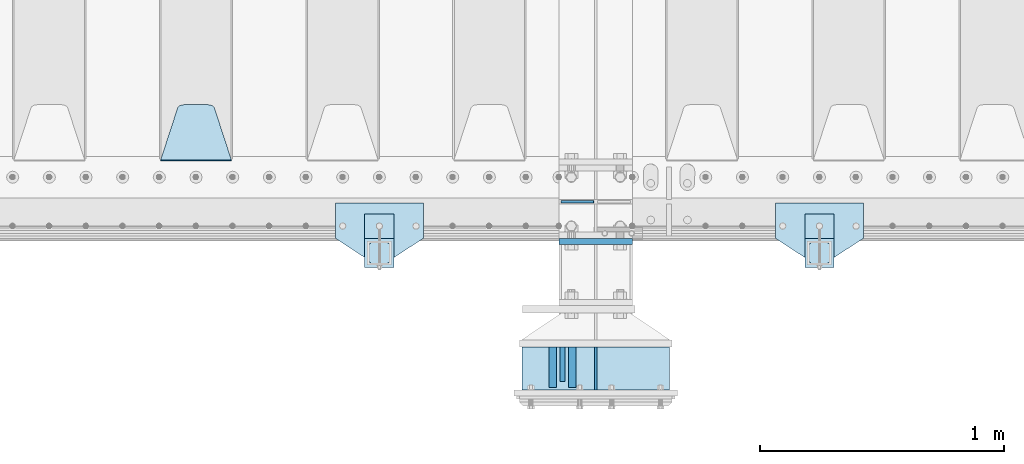
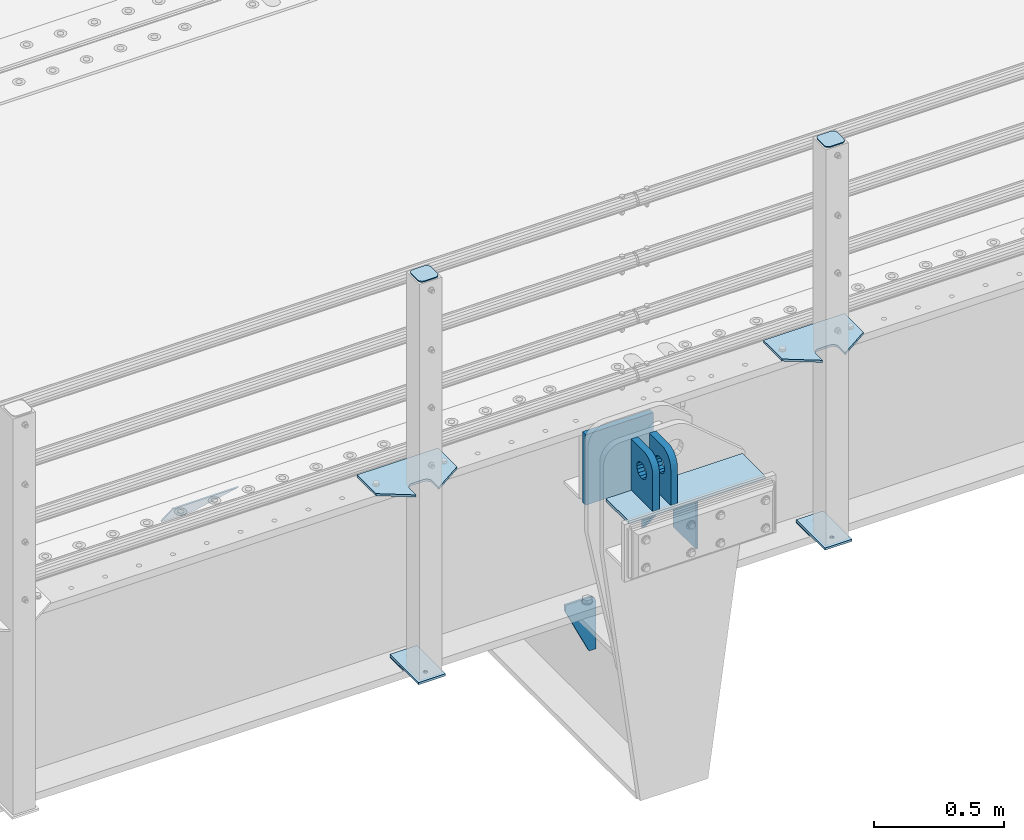
# One storey, part 207 of 242: 16 plates.
"""IFC2X3 building model written with IfcOpenShell, lengths in millimetres."""

from ifc_helpers import new_model, si_unit, frame, origin_with_axes, place, context, subcontext, project, spatial, faceted_brep, material, type_object, element, save


model = new_model("IFC2X3")

# Units and contexts
model_context = context("Model", 3, precision=1e-05, world=origin_with_axes())
body_context = subcontext(model_context, "Body", "Model", "MODEL_VIEW")
ifc_project = project(units=[si_unit("LENGTHUNIT", "METRE", prefix="MILLI"), si_unit("AREAUNIT", "SQUARE_METRE"), si_unit("VOLUMEUNIT", "CUBIC_METRE"), si_unit("MASSUNIT", "GRAM", prefix="KILO"), si_unit("TIMEUNIT", "SECOND"), si_unit("PLANEANGLEUNIT", "RADIAN"), si_unit("SOLIDANGLEUNIT", "STERADIAN"), si_unit("THERMODYNAMICTEMPERATUREUNIT", "DEGREE_CELSIUS"), si_unit("LUMINOUSINTENSITYUNIT", "LUMEN")], contexts=[model_context])

# Site, building, storey
site_placement = place(None, origin_with_axes())
site = spatial("IfcSite", under=ifc_project, at=site_placement, CompositionType="ELEMENT")
building_placement = place(site_placement, origin_with_axes())
building = spatial("IfcBuilding", under=site, at=building_placement, Name="Standard", CompositionType="ELEMENT")
storey_placement = place(building_placement, origin_with_axes())
storey = spatial("IfcBuildingStorey", under=building, at=storey_placement, Name="Undefined", CompositionType="ELEMENT", Elevation=0.0)

# Plates
ifc_material_1 = material(Name="STEEL/S355N")
plate_type_1 = type_object("IfcPlateType", PredefinedType="NOTDEFINED")
plate_1_placement = place(storey_placement, frame((-28414.9999999406, -24770.0000000349, -24.0000182225592), z_axis=(0.0, 0.0, -1.0), x_axis=(0.0, 1.0, 0.0)))
element("IfcPlate", 1, at=plate_1_placement, inside=storey, type_object=plate_type_1, material=ifc_material_1, context=body_context, shape_type="Brep", body=[
    faceted_brep([(0.0, -5.0, 0.0), (0.0, -5.0, 222.0), (0.0, 5.0, 222.0), (0.0, 5.0, 0.0), (175.0, -5.0, 222.0), (175.0, 5.0, 222.0), (175.0, -5.0, 0.0), (175.0, 5.0, 0.0)], [[[0, 1, 2, 3]], [[1, 4, 5, 2]], [[4, 6, 7, 5]], [[6, 0, 3, 7]], [[5, 7, 3, 2]], [[6, 4, 1, 0]]]),
])
plate_type_2 = type_object("IfcPlateType", PredefinedType="NOTDEFINED")
plate_2_placement = place(storey_placement, frame((-28550.5000001149, -24734.999999964, -24.0000182219301), z_axis=(0.0, 0.0, -1.0), x_axis=(0.0, 1.0, 0.0)))
element("IfcPlate", 2, at=plate_2_placement, inside=storey, type_object=plate_type_2, material=ifc_material_1, context=body_context, shape_type="Brep", body=[
    faceted_brep([(0.0, -10.0, 0.0), (140.0, -10.0, 180.0), (140.0, 10.0, 180.0), (0.0, 10.0, 0.0), (140.0, -10.0, -1.81898940354586e-12), (140.0, 10.0, -1.81898940354586e-12)], [[[0, 1, 2, 3]], [[1, 4, 5, 2]], [[4, 0, 3, 5]], [[5, 3, 2]], [[4, 1, 0]]]),
])
plate_type_3 = type_object("IfcPlateType", PredefinedType="NOTDEFINED")
plate_3_placement = place(storey_placement, frame((-28510.5000001165, -24594.9999999639, -10.0000182219628), z_axis=(0.0, -1.0, 0.0), x_axis=(0.0, 0.0, 1.0)))
element("IfcPlate", 3, at=plate_3_placement, inside=storey, type_object=plate_type_3, material=ifc_material_1, context=body_context, shape_type="Brep", body=[
    faceted_brep([(125.840713002497, -14.9999995435392, 45.8164574470829), (125.840713002497, 15.0000004564608, 45.8164571470843), (113.837049096103, 15.0000005366674, 53.8370489461013), (113.837049096103, -14.9999994633326, 53.8370492460999), (105.816457297088, 15.0000006567025, 65.8407128524959), (105.816457297088, -14.9999993432975, 65.8407131524946), (103.000000000005, 15.0000007982962, 79.9999998500025), (103.000000000005, -14.9999992017038, 80.0000001500011), (105.816457297088, 15.00000093989, 94.1592868475091), (105.816457297088, -14.99999906011, 94.1592871475077), (113.837049096103, 15.0000010599251, 106.162950753904), (113.837049096103, -14.9999989400749, 106.162951053902), (125.840713002497, 15.0000011401316, 114.183542552921), (125.840713002497, -14.9999988598684, 114.183542852919), (140.000000000005, 15.0000011682969, 116.999999850003), (140.000000000005, -14.9999988317031, 117.000000150001), (154.159286997514, 15.0000011401316, 114.183542552921), (154.159286997514, -14.9999988598684, 114.183542852919), (166.162950903908, 15.0000010599251, 106.162950753904), (166.162950903908, -14.9999989400749, 106.162951053902), (174.183542702923, 15.00000093989, 94.1592868475091), (174.183542702923, -14.99999906011, 94.1592871475077), (177.000000000005, 15.0000007982962, 79.9999998500025), (177.000000000005, -14.9999992017038, 80.0000001500011), (174.183542702923, 15.0000006567025, 65.8407128524959), (174.183542702923, -14.9999993432975, 65.8407131524946), (166.162950903908, 15.0000005366674, 53.8370489461013), (166.162950903908, -14.9999994633326, 53.8370492460999), (154.159286997514, 15.0000004564608, 45.8164571470843), (154.159286997514, -14.9999995435392, 45.8164574470829), (140.000000000005, 15.0000004282956, 42.9999998500025), (140.000000000005, -14.9999995717044, 43.0000001500011), (240.000015258789, -14.9999999999964, -2.03726813197136e-10), (240.001666876698, -15.0, 94.9959403776229), (237.616787699976, -15.0, 113.113322498935), (230.624045898169, -15.0, 129.996116868067), (219.499985670386, -14.9999999999964, 144.493787979864), (205.002693976271, -14.9999999999964, 155.618342674454), (188.120138118986, -15.0, 162.611660295068), (170.002837349484, -15.0, 164.997157401463), (-1.40620068123098e-06, -15.0, 165.0), (0.0, -15.0, 0.0), (0.0, 15.0, 0.0), (240.000015258789, 15.0000000000036, -2.03726813197136e-10), (240.001666876698, 15.0, 94.9959403776265), (237.616787699976, 15.0, 113.113322498935), (230.624045898169, 15.0, 129.996116868067), (219.499985670386, 15.0000000000036, 144.493787979864), (205.002693976271, 15.0000000000036, 155.618342674454), (188.120138118986, 15.0, 162.611660295068), (170.002837349484, 15.0, 164.997157401463), (-1.40620068123098e-06, 15.0, 165.000000000004)], [[[0, 1, 2, 3]], [[3, 2, 4, 5]], [[5, 4, 6, 7]], [[7, 6, 8, 9]], [[9, 8, 10, 11]], [[11, 10, 12, 13]], [[13, 12, 14, 15]], [[15, 14, 16, 17]], [[17, 16, 18, 19]], [[19, 18, 20, 21]], [[21, 20, 22, 23]], [[23, 22, 24, 25]], [[25, 24, 26, 27]], [[27, 26, 28, 29]], [[29, 28, 30, 31]], [[31, 30, 1, 0]], [[32, 33, 34, 35, 36, 37, 38, 39, 40, 41], [3, 5, 7, 9, 11, 13, 15, 17, 19, 21, 23, 25, 27, 29, 31, 0]], [[32, 41, 42, 43]], [[33, 32, 43, 44]], [[34, 33, 44, 45]], [[35, 34, 45, 46]], [[36, 35, 46, 47]], [[37, 36, 47, 48]], [[38, 37, 48, 49]], [[39, 38, 49, 50]], [[40, 39, 50, 51]], [[41, 40, 51, 42]], [[50, 49, 48, 47, 46, 45, 44, 43, 42, 51], [26, 24, 22, 20, 18, 16, 14, 12, 10, 8, 6, 4, 2, 1, 30, 28]]]),
])
plate_4_placement = place(storey_placement, frame((-28590.5000001148, -24594.9999999639, -10.0000182219628), z_axis=(0.0, -1.0, 0.0), x_axis=(0.0, 0.0, 1.0)))
element("IfcPlate", 4, at=plate_4_placement, inside=storey, type_object=plate_type_3, material=ifc_material_1, context=body_context, shape_type="Brep", body=[
    faceted_brep([(125.840713002497, -14.9999995435392, 45.8164574470829), (125.840713002497, 15.0000004564608, 45.8164571470843), (113.837049096103, 15.0000005366674, 53.8370489461013), (113.837049096103, -14.9999994633326, 53.8370492460999), (105.816457297088, 15.0000006567025, 65.8407128524959), (105.816457297088, -14.9999993432975, 65.8407131524946), (103.000000000005, 15.0000007982962, 79.9999998500025), (103.000000000005, -14.9999992017038, 80.0000001500011), (105.816457297088, 15.00000093989, 94.1592868475091), (105.816457297088, -14.99999906011, 94.1592871475077), (113.837049096103, 15.0000010599251, 106.162950753904), (113.837049096103, -14.9999989400749, 106.162951053902), (125.840713002497, 15.0000011401316, 114.183542552921), (125.840713002497, -14.9999988598684, 114.183542852919), (140.000000000005, 15.0000011682969, 116.999999850003), (140.000000000005, -14.9999988317031, 117.000000150001), (154.159286997514, 15.0000011401316, 114.183542552921), (154.159286997514, -14.9999988598684, 114.183542852919), (166.162950903908, 15.0000010599251, 106.162950753904), (166.162950903908, -14.9999989400749, 106.162951053902), (174.183542702923, 15.00000093989, 94.1592868475091), (174.183542702923, -14.99999906011, 94.1592871475077), (177.000000000005, 15.0000007982962, 79.9999998500025), (177.000000000005, -14.9999992017038, 80.0000001500011), (174.183542702923, 15.0000006567025, 65.8407128524959), (174.183542702923, -14.9999993432975, 65.8407131524946), (166.162950903908, 15.0000005366674, 53.8370489461013), (166.162950903908, -14.9999994633326, 53.8370492460999), (154.159286997514, 15.0000004564608, 45.8164571470843), (154.159286997514, -14.9999995435392, 45.8164574470829), (140.000000000005, 15.0000004282956, 42.9999998500025), (140.000000000005, -14.9999995717044, 43.0000001500011), (240.000015258789, -14.9999999999964, -2.03726813197136e-10), (240.0, -15.0, 95.0), (237.614807840235, -15.0, 113.117333157177), (230.621778264911, -15.0, 130.0), (219.497474683058, -15.0, 144.497474683059), (205.0, -15.0, 155.621778264911), (188.117333157176, -15.0, 162.614807840237), (170.0, -15.0, 165.0), (-1.40620068123098e-06, -15.0, 165.0), (0.0, -15.0, 0.0), (0.0, 15.0, 0.0), (240.000015258789, 15.0000000000036, -2.03726813197136e-10), (240.0, 15.0, 95.0), (237.614807840235, 15.0, 113.117333157177), (230.621778264911, 15.0, 130.0), (219.497474683058, 15.0, 144.497474683059), (205.0, 15.0, 155.621778264911), (188.117333157176, 15.0, 162.614807840237), (170.0, 15.0, 165.0), (-1.40620068123098e-06, 15.0, 165.000000000004)], [[[0, 1, 2, 3]], [[3, 2, 4, 5]], [[5, 4, 6, 7]], [[7, 6, 8, 9]], [[9, 8, 10, 11]], [[11, 10, 12, 13]], [[13, 12, 14, 15]], [[15, 14, 16, 17]], [[17, 16, 18, 19]], [[19, 18, 20, 21]], [[21, 20, 22, 23]], [[23, 22, 24, 25]], [[25, 24, 26, 27]], [[27, 26, 28, 29]], [[29, 28, 30, 31]], [[31, 30, 1, 0]], [[32, 33, 34, 35, 36, 37, 38, 39, 40, 41], [3, 5, 7, 9, 11, 13, 15, 17, 19, 21, 23, 25, 27, 29, 31, 0]], [[32, 41, 42, 43]], [[33, 32, 43, 44]], [[34, 33, 44, 45]], [[35, 34, 45, 46]], [[36, 35, 46, 47]], [[37, 36, 47, 48]], [[38, 37, 48, 49]], [[39, 38, 49, 50]], [[40, 39, 50, 51]], [[41, 40, 51, 42]], [[50, 49, 48, 47, 46, 45, 44, 43, 42, 51], [26, 24, 22, 20, 18, 16, 14, 12, 10, 8, 6, 4, 2, 1, 30, 28]]]),
])
ifc_material_2 = material(Name="STEEL/S355J2")
plate_type_4 = type_object("IfcPlateType", PredefinedType="NOTDEFINED")
plate_5_placement = place(storey_placement, frame((-29120.0, -24005.0, 5.00000000004911), z_axis=(0.0, -1.0, 0.0), x_axis=(-1.0, 0.0, 0.0)))
element("IfcPlate", 5, at=plate_5_placement, inside=storey, type_object=plate_type_4, material=ifc_material_2, context=body_context, shape_type="Brep", body=[
    faceted_brep([(0.0, -5.0, 0.0), (2.31396552408114e-06, -5.0, 145.0), (2.31396552408114e-06, 5.0, 145.0), (0.0, 5.0, 0.0), (130.0, -5.0, 230.0), (130.0, 5.0, 230.0), (130.0, -5.0, 180.0), (130.0, 5.0, 180.0), (130.48036798992, -5.0, 175.122741949595), (130.48036798992, 5.0, 175.122741949595), (131.903011687216, -5.0, 170.432914190871), (131.903011687216, 5.0, 170.432914190871), (134.213259692435, -5.0, 166.110744174512), (134.213259692435, 5.0, 166.110744174512), (137.322330470335, -5.0, 162.322330470335), (137.322330470335, 5.0, 162.322330470335), (141.110744174512, -5.0, 159.213259692435), (141.110744174512, 5.0, 159.213259692435), (145.432914190871, -5.0, 156.903011687216), (145.432914190871, 5.0, 156.903011687216), (150.122741949595, -5.0, 155.48036798992), (150.122741949595, 5.0, 155.48036798992), (155.0, -5.0, 155.0), (155.0, 5.0, 155.0), (205.0, -5.0, 155.0), (205.0, 5.0, 155.0), (209.877258050405, -5.0, 155.48036798992), (209.877258050405, 5.0, 155.48036798992), (214.567085809129, -5.0, 156.903011687216), (214.567085809129, 5.0, 156.903011687216), (218.889255825488, -5.0, 159.213259692435), (218.889255825488, 5.0, 159.213259692435), (222.677669529665, -5.0, 162.322330470335), (222.677669529665, 5.0, 162.322330470335), (225.786740307565, -5.0, 166.110744174512), (225.786740307565, 5.0, 166.110744174512), (228.096988312784, -5.0, 170.432914190871), (228.096988312784, 5.0, 170.432914190871), (229.51963201008, -5.0, 175.122741949595), (229.51963201008, 5.0, 175.122741949595), (230.0, -5.0, 180.0), (230.0, 5.0, 180.0), (230.0, -5.0, 230.0), (230.0, 5.0, 230.0), (360.0, -5.0, 145.0), (360.0, 5.0, 145.0), (360.0, -5.0, -7.27595761418343e-12), (360.0, 5.0, -7.27595761418343e-12)], [[[0, 1, 2, 3]], [[1, 4, 5, 2]], [[4, 6, 7, 5]], [[6, 8, 9, 7]], [[8, 10, 11, 9]], [[10, 12, 13, 11]], [[12, 14, 15, 13]], [[14, 16, 17, 15]], [[16, 18, 19, 17]], [[18, 20, 21, 19]], [[20, 22, 23, 21]], [[22, 24, 25, 23]], [[24, 26, 27, 25]], [[26, 28, 29, 27]], [[28, 30, 31, 29]], [[30, 32, 33, 31]], [[32, 34, 35, 33]], [[34, 36, 37, 35]], [[36, 38, 39, 37]], [[38, 40, 41, 39]], [[40, 42, 43, 41]], [[42, 44, 45, 43]], [[44, 46, 47, 45]], [[46, 0, 3, 47]], [[5, 7, 9, 11, 13, 15, 17, 19, 21, 23, 25, 27, 29, 31, 33, 35, 37, 39, 41, 43, 45, 47, 3, 2]], [[46, 44, 42, 40, 38, 36, 34, 32, 30, 28, 26, 24, 22, 20, 18, 16, 14, 12, 10, 8, 6, 4, 1, 0]]]),
])
plate_6_placement = place(storey_placement, frame((-27320.0, -24005.0, 5.00000000004911), z_axis=(0.0, -1.0, 0.0), x_axis=(-1.0, 0.0, 0.0)))
element("IfcPlate", 6, at=plate_6_placement, inside=storey, type_object=plate_type_4, material=ifc_material_2, context=body_context, shape_type="Brep", body=[
    faceted_brep([(0.0, -5.0, 0.0), (2.31396552408114e-06, -5.0, 145.0), (2.31396552408114e-06, 5.0, 145.0), (0.0, 5.0, 0.0), (130.0, -5.0, 230.0), (130.0, 5.0, 230.0), (130.0, -5.0, 180.0), (130.0, 5.0, 180.0), (130.48036798992, -5.0, 175.122741949595), (130.48036798992, 5.0, 175.122741949595), (131.903011687216, -5.0, 170.432914190871), (131.903011687216, 5.0, 170.432914190871), (134.213259692435, -5.0, 166.110744174512), (134.213259692435, 5.0, 166.110744174512), (137.322330470335, -5.0, 162.322330470335), (137.322330470335, 5.0, 162.322330470335), (141.110744174512, -5.0, 159.213259692435), (141.110744174512, 5.0, 159.213259692435), (145.432914190871, -5.0, 156.903011687216), (145.432914190871, 5.0, 156.903011687216), (150.122741949595, -5.0, 155.48036798992), (150.122741949595, 5.0, 155.48036798992), (155.0, -5.0, 155.0), (155.0, 5.0, 155.0), (205.0, -5.0, 155.0), (205.0, 5.0, 155.0), (209.877258050405, -5.0, 155.48036798992), (209.877258050405, 5.0, 155.48036798992), (214.567085809129, -5.0, 156.903011687216), (214.567085809129, 5.0, 156.903011687216), (218.889255825488, -5.0, 159.213259692435), (218.889255825488, 5.0, 159.213259692435), (222.677669529665, -5.0, 162.322330470335), (222.677669529665, 5.0, 162.322330470335), (225.786740307565, -5.0, 166.110744174512), (225.786740307565, 5.0, 166.110744174512), (228.096988312784, -5.0, 170.432914190871), (228.096988312784, 5.0, 170.432914190871), (229.51963201008, -5.0, 175.122741949595), (229.51963201008, 5.0, 175.122741949595), (230.0, -5.0, 180.0), (230.0, 5.0, 180.0), (230.0, -5.0, 230.0), (230.0, 5.0, 230.0), (360.0, -5.0, 145.0), (360.0, 5.0, 145.0), (360.0, -5.0, -7.27595761418343e-12), (360.0, 5.0, -7.27595761418343e-12)], [[[0, 1, 2, 3]], [[1, 4, 5, 2]], [[4, 6, 7, 5]], [[6, 8, 9, 7]], [[8, 10, 11, 9]], [[10, 12, 13, 11]], [[12, 14, 15, 13]], [[14, 16, 17, 15]], [[16, 18, 19, 17]], [[18, 20, 21, 19]], [[20, 22, 23, 21]], [[22, 24, 25, 23]], [[24, 26, 27, 25]], [[26, 28, 29, 27]], [[28, 30, 31, 29]], [[30, 32, 33, 31]], [[32, 34, 35, 33]], [[34, 36, 37, 35]], [[36, 38, 39, 37]], [[38, 40, 41, 39]], [[40, 42, 43, 41]], [[42, 44, 45, 43]], [[44, 46, 47, 45]], [[46, 0, 3, 47]], [[5, 7, 9, 11, 13, 15, 17, 19, 21, 23, 25, 27, 29, 31, 33, 35, 37, 39, 41, 43, 45, 47, 3, 2]], [[46, 44, 42, 40, 38, 36, 34, 32, 30, 28, 26, 24, 22, 20, 18, 16, 14, 12, 10, 8, 6, 4, 1, 0]]]),
])
plate_type_5 = type_object("IfcPlateType", PredefinedType="NOTDEFINED")
for number, where, z_axis, x_axis in (
    (7, (-29240.0000000001, -24050.0000000002, -850.000000000002), (0.0, -1.0, 0.0), (-1.0, 0.0, 0.0)),
    (8, (-27440.0000000001, -24050.0000000002, -850.000000000002), (0.0, -1.0, 0.0), (-1.0, 0.0, 0.0)),
):
    element("IfcPlate", number, at=place(storey_placement, frame(where, z_axis=z_axis, x_axis=x_axis)), inside=storey, type_object=plate_type_5, material=ifc_material_2, context=body_context, shape_type="Brep", body=[
        faceted_brep([(53.6360389691836, -5.0, 176.363961030471), (53.6360389691836, 5.0, 176.363961030471), (59.9999999998618, 5.0, 178.999999999793), (59.9999999998618, -5.0, 178.999999999793), (66.3639610305399, 5.0, 176.363961030471), (66.3639610305399, -5.0, 176.363961030471), (68.9999999998618, 5.0, 169.999999999793), (68.9999999998618, -5.0, 169.999999999793), (66.3639610305399, 5.0, 163.636038969114), (66.3639610305399, -5.0, 163.636038969114), (59.9999999998618, 5.0, 160.999999999793), (59.9999999998618, -5.0, 160.999999999793), (53.6360389691836, 5.0, 163.636038969114), (53.6360389691836, -5.0, 163.636038969114), (50.9999999998618, 5.0, 169.999999999793), (50.9999999998618, -5.0, 169.999999999793), (120.0, -5.0, 0.0), (120.0, -5.0, 220.0), (0.0, -5.0, 220.0), (0.0, -5.0, 0.0), (0.0, 5.0, 0.0), (120.0, 5.0, 0.0), (120.0, 5.0, 220.0), (0.0, 5.0, 220.0)], [[[0, 1, 2, 3]], [[3, 2, 4, 5]], [[5, 4, 6, 7]], [[7, 6, 8, 9]], [[9, 8, 10, 11]], [[11, 10, 12, 13]], [[13, 12, 14, 15]], [[15, 14, 1, 0]], [[16, 17, 18, 19], [3, 5, 7, 9, 11, 13, 15, 0]], [[16, 19, 20, 21]], [[17, 16, 21, 22]], [[18, 17, 22, 23]], [[19, 18, 23, 20]], [[22, 21, 20, 23], [10, 8, 6, 4, 2, 1, 14, 12]]]),
    ])
plate_type_6 = type_object("IfcPlateType", PredefinedType="NOTDEFINED")
plate_7_placement = place(storey_placement, frame((-29344.0000000001, -24166.0000000002, 1012.50000000001), z_axis=(0.0, -1.0, 0.0), x_axis=(1.0, 0.0, 0.0)))
element("IfcPlate", 9, at=plate_7_placement, inside=storey, type_object=plate_type_6, material=ifc_material_2, context=body_context, shape_type="Brep", body=[
    faceted_brep([(0.0, -2.5, 19.0), (0.0, -2.5, 69.0), (0.0, 2.5, 69.0), (0.0, 2.5, 19.0), (0.476369668544066, -2.5, 73.2278977451715), (0.476369668544066, 2.5, 73.2278977451715), (1.88159150985302, -2.5, 77.2437910432345), (1.88159150985302, 2.5, 77.2437910432345), (4.14520183310742, -2.5, 80.8463062353148), (4.14520183310742, 2.5, 80.8463062353148), (7.15369376468516, -2.5, 83.8547981668926), (7.15369376468516, 2.5, 83.8547981668926), (10.7562089567655, -2.5, 86.118408490147), (10.7562089567655, 2.5, 86.118408490147), (14.7721022548285, -2.5, 87.5236303314559), (14.7721022548285, 2.5, 87.5236303314559), (19.0, -2.5, 88.0), (19.0, 2.5, 88.0), (69.0, -2.5, 88.0), (69.0, 2.5, 88.0), (73.2278977451715, -2.5, 87.5236303314559), (73.2278977451715, 2.5, 87.5236303314559), (77.2437910432345, -2.5, 86.118408490147), (77.2437910432345, 2.5, 86.118408490147), (80.8463062353148, -2.5, 83.8547981668926), (80.8463062353148, 2.5, 83.8547981668926), (83.8547981668926, -2.5, 80.8463062353148), (83.8547981668926, 2.5, 80.8463062353148), (86.118408490147, -2.5, 77.2437910432345), (86.118408490147, 2.5, 77.2437910432345), (87.5236303314559, -2.5, 73.2278977451715), (87.5236303314559, 2.5, 73.2278977451715), (88.0, -2.5, 69.0), (88.0, 2.5, 69.0), (88.0, -2.5, 19.0), (88.0, 2.5, 19.0), (87.5236303314559, -2.5, 14.7721022548285), (87.5236303314559, 2.5, 14.7721022548285), (86.118408490147, -2.5, 10.7562089567655), (86.118408490147, 2.5, 10.7562089567655), (83.8547981668926, -2.5, 7.15369376468516), (83.8547981668926, 2.5, 7.15369376468516), (80.8463062353148, -2.5, 4.14520183310742), (80.8463062353148, 2.5, 4.14520183310742), (77.2437910432345, -2.5, 1.88159150985302), (77.2437910432345, 2.5, 1.88159150985302), (73.2278977451715, -2.5, 0.476369668544066), (73.2278977451715, 2.5, 0.476369668544066), (69.0, -2.5, 0.0), (69.0, 2.5, 0.0), (19.0, -2.5, 0.0), (19.0, 2.5, 0.0), (14.7721022548285, -2.5, 0.476369668544066), (14.7721022548285, 2.5, 0.476369668544066), (10.7562089567655, -2.5, 1.88159150985302), (10.7562089567655, 2.5, 1.88159150985302), (7.15369376468516, -2.5, 4.14520183310742), (7.15369376468516, 2.5, 4.14520183310742), (4.14520183310742, -2.5, 7.15369376468516), (4.14520183310742, 2.5, 7.15369376468516), (1.88159150985302, -2.5, 10.7562089567655), (1.88159150985302, 2.5, 10.7562089567655), (0.476369668544066, -2.5, 14.7721022548285), (0.476369668544066, 2.5, 14.7721022548285)], [[[0, 1, 2, 3]], [[1, 4, 5, 2]], [[4, 6, 7, 5]], [[6, 8, 9, 7]], [[8, 10, 11, 9]], [[10, 12, 13, 11]], [[12, 14, 15, 13]], [[14, 16, 17, 15]], [[16, 18, 19, 17]], [[18, 20, 21, 19]], [[20, 22, 23, 21]], [[22, 24, 25, 23]], [[24, 26, 27, 25]], [[26, 28, 29, 27]], [[28, 30, 31, 29]], [[30, 32, 33, 31]], [[32, 34, 35, 33]], [[34, 36, 37, 35]], [[36, 38, 39, 37]], [[38, 40, 41, 39]], [[40, 42, 43, 41]], [[42, 44, 45, 43]], [[44, 46, 47, 45]], [[46, 48, 49, 47]], [[48, 50, 51, 49]], [[50, 52, 53, 51]], [[52, 54, 55, 53]], [[54, 56, 57, 55]], [[56, 58, 59, 57]], [[58, 60, 61, 59]], [[60, 62, 63, 61]], [[62, 0, 3, 63]], [[5, 7, 9, 11, 13, 15, 17, 19, 21, 23, 25, 27, 29, 31, 33, 35, 37, 39, 41, 43, 45, 47, 49, 51, 53, 55, 57, 59, 61, 63, 3, 2]], [[62, 60, 58, 56, 54, 52, 50, 48, 46, 44, 42, 40, 38, 36, 34, 32, 30, 28, 26, 24, 22, 20, 18, 16, 14, 12, 10, 8, 6, 4, 1, 0]]]),
])
plate_8_placement = place(storey_placement, frame((-27544.0000000001, -24166.0000000002, 1012.50000000001), z_axis=(0.0, -1.0, 0.0), x_axis=(1.0, 0.0, 0.0)))
element("IfcPlate", 10, at=plate_8_placement, inside=storey, type_object=plate_type_6, material=ifc_material_2, context=body_context, shape_type="Brep", body=[
    faceted_brep([(0.0, -2.5, 19.0), (0.0, -2.5, 69.0), (0.0, 2.5, 69.0), (0.0, 2.5, 19.0), (0.476369668544066, -2.5, 73.2278977451715), (0.476369668544066, 2.5, 73.2278977451715), (1.88159150985302, -2.5, 77.2437910432345), (1.88159150985302, 2.5, 77.2437910432345), (4.14520183310742, -2.5, 80.8463062353148), (4.14520183310742, 2.5, 80.8463062353148), (7.15369376468516, -2.5, 83.8547981668926), (7.15369376468516, 2.5, 83.8547981668926), (10.7562089567655, -2.5, 86.118408490147), (10.7562089567655, 2.5, 86.118408490147), (14.7721022548285, -2.5, 87.5236303314559), (14.7721022548285, 2.5, 87.5236303314559), (19.0, -2.5, 88.0), (19.0, 2.5, 88.0), (69.0, -2.5, 88.0), (69.0, 2.5, 88.0), (73.2278977451715, -2.5, 87.5236303314559), (73.2278977451715, 2.5, 87.5236303314559), (77.2437910432345, -2.5, 86.118408490147), (77.2437910432345, 2.5, 86.118408490147), (80.8463062353148, -2.5, 83.8547981668926), (80.8463062353148, 2.5, 83.8547981668926), (83.8547981668926, -2.5, 80.8463062353148), (83.8547981668926, 2.5, 80.8463062353148), (86.118408490147, -2.5, 77.2437910432345), (86.118408490147, 2.5, 77.2437910432345), (87.5236303314559, -2.5, 73.2278977451715), (87.5236303314559, 2.5, 73.2278977451715), (88.0, -2.5, 69.0), (88.0, 2.5, 69.0), (88.0, -2.5, 19.0), (88.0, 2.5, 19.0), (87.5236303314559, -2.5, 14.7721022548285), (87.5236303314559, 2.5, 14.7721022548285), (86.118408490147, -2.5, 10.7562089567655), (86.118408490147, 2.5, 10.7562089567655), (83.8547981668926, -2.5, 7.15369376468516), (83.8547981668926, 2.5, 7.15369376468516), (80.8463062353148, -2.5, 4.14520183310742), (80.8463062353148, 2.5, 4.14520183310742), (77.2437910432345, -2.5, 1.88159150985302), (77.2437910432345, 2.5, 1.88159150985302), (73.2278977451715, -2.5, 0.476369668544066), (73.2278977451715, 2.5, 0.476369668544066), (69.0, -2.5, 0.0), (69.0, 2.5, 0.0), (19.0, -2.5, 0.0), (19.0, 2.5, 0.0), (14.7721022548285, -2.5, 0.476369668544066), (14.7721022548285, 2.5, 0.476369668544066), (10.7562089567655, -2.5, 1.88159150985302), (10.7562089567655, 2.5, 1.88159150985302), (7.15369376468516, -2.5, 4.14520183310742), (7.15369376468516, 2.5, 4.14520183310742), (4.14520183310742, -2.5, 7.15369376468516), (4.14520183310742, 2.5, 7.15369376468516), (1.88159150985302, -2.5, 10.7562089567655), (1.88159150985302, 2.5, 10.7562089567655), (0.476369668544066, -2.5, 14.7721022548285), (0.476369668544066, 2.5, 14.7721022548285)], [[[0, 1, 2, 3]], [[1, 4, 5, 2]], [[4, 6, 7, 5]], [[6, 8, 9, 7]], [[8, 10, 11, 9]], [[10, 12, 13, 11]], [[12, 14, 15, 13]], [[14, 16, 17, 15]], [[16, 18, 19, 17]], [[18, 20, 21, 19]], [[20, 22, 23, 21]], [[22, 24, 25, 23]], [[24, 26, 27, 25]], [[26, 28, 29, 27]], [[28, 30, 31, 29]], [[30, 32, 33, 31]], [[32, 34, 35, 33]], [[34, 36, 37, 35]], [[36, 38, 39, 37]], [[38, 40, 41, 39]], [[40, 42, 43, 41]], [[42, 44, 45, 43]], [[44, 46, 47, 45]], [[46, 48, 49, 47]], [[48, 50, 51, 49]], [[50, 52, 53, 51]], [[52, 54, 55, 53]], [[54, 56, 57, 55]], [[56, 58, 59, 57]], [[58, 60, 61, 59]], [[60, 62, 63, 61]], [[62, 0, 3, 63]], [[5, 7, 9, 11, 13, 15, 17, 19, 21, 23, 25, 27, 29, 31, 33, 35, 37, 39, 41, 43, 45, 47, 49, 51, 53, 55, 57, 59, 61, 63, 3, 2]], [[62, 60, 58, 56, 54, 52, 50, 48, 46, 44, 42, 40, 38, 36, 34, 32, 30, 28, 26, 24, 22, 20, 18, 16, 14, 12, 10, 8, 6, 4, 1, 0]]]),
])
plate_type_7 = type_object("IfcPlateType", PredefinedType="NOTDEFINED")
for number, where, z_axis, x_axis in (
    (11, (-29240.0000000001, -24050.0000000002, -857.500000000002), (0.0, -1.0, 0.0), (-1.0, 0.0, 0.0)),
    (12, (-27440.0000000001, -24050.0000000002, -857.500000000002), (0.0, -1.0, 0.0), (-1.0, 0.0, 0.0)),
):
    element("IfcPlate", number, at=place(storey_placement, frame(where, z_axis=z_axis, x_axis=x_axis)), inside=storey, type_object=plate_type_7, material=ifc_material_2, context=body_context, shape_type="Brep", body=[
        faceted_brep([(0.0, -2.5, 0.0), (0.0, -2.5, 100.0), (0.0, 2.5, 100.0), (0.0, 2.5, 0.0), (120.0, -2.5, 100.0), (120.0, 2.5, 100.0), (120.0, -2.5, 0.0), (120.0, 2.5, 0.0)], [[[0, 1, 2, 3]], [[1, 4, 5, 2]], [[4, 6, 7, 5]], [[6, 0, 3, 7]], [[5, 7, 3, 2]], [[6, 4, 1, 0]]]),
    ])
plate_type_8 = type_object("IfcPlateType", PredefinedType="NOTDEFINED")
plate_9_placement = place(storey_placement, frame((-28421.4999999409, -24000.0000000349, -925.000018222557), z_axis=(0.0, 0.0, -1.0), x_axis=(-1.0, 0.0, 0.0)))
element("IfcPlate", 13, at=plate_9_placement, inside=storey, type_object=plate_type_8, material=ifc_material_1, context=body_context, shape_type="Brep", body=[
    faceted_brep([(0.0, -5.0, 27.0), (0.0, -5.0, 250.0), (0.0, 5.0, 250.0), (0.0, 5.0, 27.0), (30.0, -5.0, 250.0), (30.0, 5.0, 250.0), (135.0, -5.0, 30.0), (135.0, 5.0, 30.0), (135.0, -5.0, 0.0), (135.0, 5.0, 0.0), (27.0, -5.0, 0.0), (27.0, 5.0, 0.0), (22.3114992029914, -5.0, 0.410190668670339), (22.3114992029914, 5.0, 0.410190668670339), (17.7654561302079, -5.0, 1.62829923878041), (17.7654561302079, 5.0, 1.62829923878041), (13.5, -5.0, 3.61731409782021), (13.5, 5.0, 3.61731409782021), (9.64473453846222, -5.0, 6.31680003578765), (9.64473453846222, 5.0, 6.31680003578765), (6.31680003578731, -5.0, 9.64473453846347), (6.31680003578731, 5.0, 9.64473453846347), (3.61731409782078, -5.0, 13.5), (3.61731409782078, 5.0, 13.5), (1.62829923877871, -5.0, 17.765456130207), (1.62829923877871, 5.0, 17.765456130207), (0.410190668670111, -5.0, 22.3114992029929), (0.410190668670111, 5.0, 22.3114992029929)], [[[0, 1, 2, 3]], [[1, 4, 5, 2]], [[4, 6, 7, 5]], [[6, 8, 9, 7]], [[8, 10, 11, 9]], [[10, 12, 13, 11]], [[12, 14, 15, 13]], [[14, 16, 17, 15]], [[16, 18, 19, 17]], [[18, 20, 21, 19]], [[20, 22, 23, 21]], [[22, 24, 25, 23]], [[24, 26, 27, 25]], [[26, 0, 3, 27]], [[5, 7, 9, 11, 13, 15, 17, 19, 21, 23, 25, 27, 3, 2]], [[26, 24, 22, 20, 18, 16, 14, 12, 10, 8, 6, 4, 1, 0]]]),
])
ifc_material_3 = material()
plate_type_9 = type_object("IfcPlateType", PredefinedType="NOTDEFINED")
plate_10_placement = place(storey_placement, frame((-28112.4999999399, -24595.000000035, -17.0000182225592), z_axis=(0.0, -1.0, 0.0), x_axis=(-1.0, 0.0, 0.0)))
element("IfcPlate", 14, at=plate_10_placement, inside=storey, type_object=plate_type_9, material=ifc_material_3, context=body_context, shape_type="Brep", body=[
    faceted_brep([(0.0, -7.0, 0.0), (0.0, -7.0, 175.0), (0.0, 7.0, 175.0), (0.0, 7.0, 0.0), (605.0, -7.0, 175.0), (605.0, 7.0, 175.0), (605.0, -7.0, 0.0), (605.0, 7.0, 0.0)], [[[0, 1, 2, 3]], [[1, 4, 5, 2]], [[4, 6, 7, 5]], [[6, 0, 3, 7]], [[5, 7, 3, 2]], [[6, 4, 1, 0]]]),
])
plate_type_10 = type_object("IfcPlateType", PredefinedType="NOTDEFINED")
plate_11_placement = place(storey_placement, frame((-28564.9999999412, -24162.5000000349, -350.000018222559), z_axis=(0.0, 0.0, 1.0), x_axis=(1.0, 0.0, 0.0)))
element("IfcPlate", 15, at=plate_11_placement, inside=storey, type_object=plate_type_10, material=ifc_material_1, context=body_context, shape_type="Brep", body=[
    faceted_brep([(0.0, -12.5, 0.0), (0.0, -12.5, 330.0), (0.0, 12.5, 330.0), (0.0, 12.5, 0.0), (300.0, -12.5, 330.0), (300.0, 12.5, 330.0), (300.0, -12.5, 0.0), (300.0, 12.5, 0.0)], [[[0, 1, 2, 3]], [[1, 4, 5, 2]], [[4, 6, 7, 5]], [[6, 0, 3, 7]], [[5, 7, 3, 2]], [[6, 4, 1, 0]]]),
])
plate_type_11 = type_object("IfcPlateType", PredefinedType="NOTDEFINED")
plate_12_placement = place(storey_placement, frame((-29905.0, -23831.767766953, -1.76776695296758), z_axis=(0.0, 0.707106781186547, -0.707106781186548), x_axis=(-1.0, 0.0, 0.0)))
element("IfcPlate", 16, at=plate_12_placement, inside=storey, type_object=plate_type_11, material=ifc_material_1, context=body_context, shape_type="Brep", body=[
    faceted_brep([(0.0, -2.5, 0.0), (69.345504679477, -2.50000000000182, 300.171731424829), (69.345504679477, 2.5, 300.171731424829), (0.0, 2.5, 0.0), (70.9274061199576, -2.5, 304.897442415398), (70.9274061199576, 2.5, 304.897442415398), (73.3818627772307, -2.5, 309.234538108525), (73.3818627772307, 2.50000000000182, 309.234538108529), (76.6187032999551, -2.5, 313.023683126101), (76.6187032999551, 2.50000000000182, 313.023683126103), (80.5190132704993, -2.5, 316.12567259537), (80.5190132704993, 2.5, 316.12567259537), (84.9395038596849, -2.5, 318.426546230474), (84.9395038596849, 2.50000000000182, 318.426546230476), (89.7177759439219, -2.49999999999818, 319.841774983273), (89.7177759439219, 2.50000000000182, 319.841774983273), (94.678286292652, -2.5, 320.319366455076), (94.678286292652, 2.5, 320.319366455076), (195.321713707348, -2.5, 320.319366455076), (195.321713707348, 2.5, 320.319366455076), (200.282224056078, -2.5, 319.841774983272), (200.282224056078, 2.50000000000182, 319.841774983273), (205.060496140315, -2.5, 318.426546230474), (205.060496140315, 2.49999999999818, 318.426546230474), (209.480986729501, -2.49999999999818, 316.12567259537), (209.480986729501, 2.5, 316.12567259537), (213.381296700045, -2.5, 313.023683126101), (213.381296700045, 2.49999999999818, 313.023683126101), (216.618137222769, -2.5, 309.234538108525), (216.618137222769, 2.5, 309.234538108523), (219.072593880042, -2.49999999999818, 304.897442415398), (219.072593880042, 2.50000000000182, 304.897442415398), (220.654495320523, -2.50000000000182, 300.171731424829), (220.654495320523, 2.5, 300.171731424829), (290.0, -2.5, 0.0), (290.0, 2.5, -1.81898940354586e-12)], [[[0, 1, 2, 3]], [[1, 4, 5, 2]], [[4, 6, 7, 5]], [[6, 8, 9, 7]], [[8, 10, 11, 9]], [[10, 12, 13, 11]], [[12, 14, 15, 13]], [[14, 16, 17, 15]], [[16, 18, 19, 17]], [[18, 20, 21, 19]], [[20, 22, 23, 21]], [[22, 24, 25, 23]], [[24, 26, 27, 25]], [[26, 28, 29, 27]], [[28, 30, 31, 29]], [[30, 32, 33, 31]], [[32, 34, 35, 33]], [[34, 0, 3, 35]], [[5, 7, 9, 11, 13, 15, 17, 19, 21, 23, 25, 27, 29, 31, 33, 35, 3, 2]], [[34, 32, 30, 28, 26, 24, 22, 20, 18, 16, 14, 12, 10, 8, 6, 4, 1, 0]]]),
])

save(model, "model.ifc")
